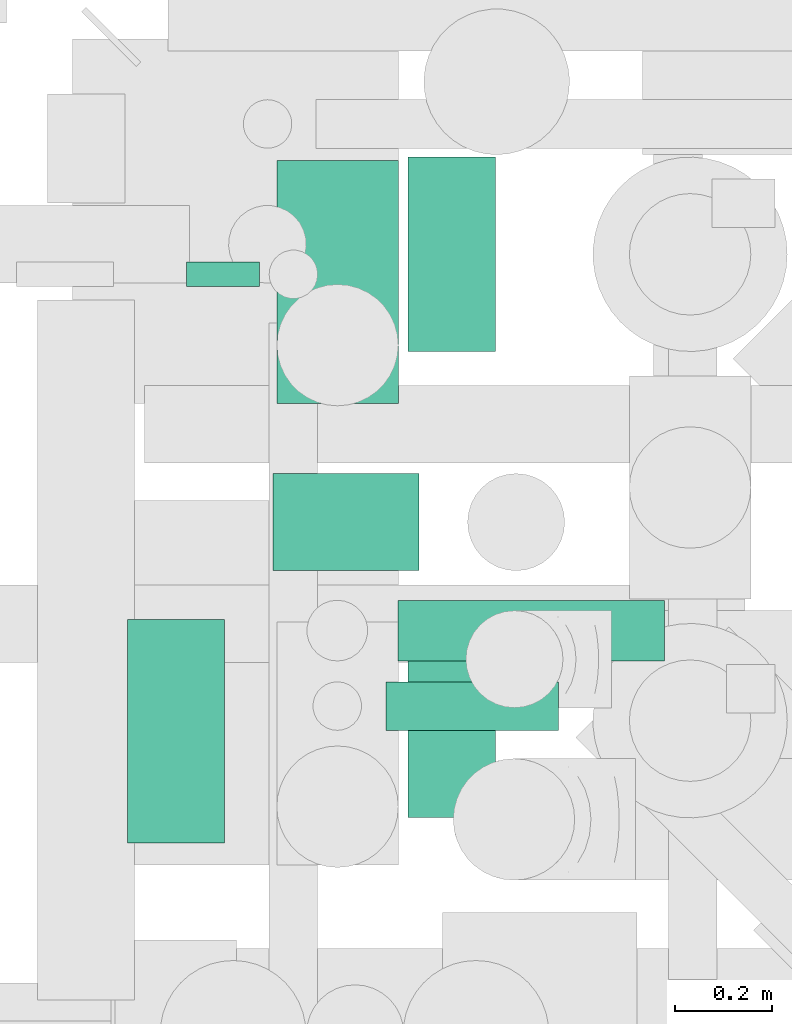
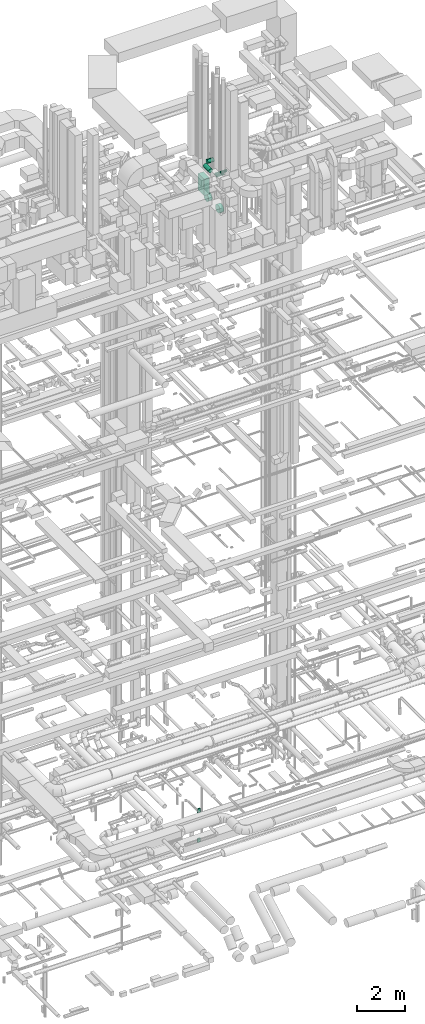
# One storey, part 226 of 337: 9 flow segments.
"""IFC2X3 building model written with IfcOpenShell, lengths in millimetres."""

from ifc_helpers import new_model, entity, si_unit, converted_unit, derived_unit, direction, frame, origin, origin_2d_with_axis, place, context, subcontext, project, spatial, rectangle, circle, extrude, type_object, element, save


model = new_model("IFC2X3")

# Units and contexts
model_context = context("Model", 3, precision=0.01, world=origin(), true_north=direction((6.12303176911189e-17, 1.0)))
body_context = subcontext(model_context, "Body", "Model", "MODEL_VIEW")
ifc_project = project(units=[si_unit("LENGTHUNIT", "METRE", prefix="MILLI"), si_unit("AREAUNIT", "SQUARE_METRE"), si_unit("VOLUMEUNIT", "CUBIC_METRE"), converted_unit("PLANEANGLEUNIT", "DEGREE", entity("IfcRatioMeasure", 0.0174532925199433), si_unit("PLANEANGLEUNIT", "RADIAN"), dimensions=[0, 0, 0, 0, 0, 0, 0]), si_unit("MASSUNIT", "GRAM", prefix="KILO"), derived_unit("MASSDENSITYUNIT", [(si_unit("MASSUNIT", "GRAM", prefix="KILO"), 1), (si_unit("LENGTHUNIT", "METRE"), -3)]), derived_unit("MOMENTOFINERTIAUNIT", [(si_unit("LENGTHUNIT", "METRE"), 4)]), si_unit("TIMEUNIT", "SECOND"), si_unit("FREQUENCYUNIT", "HERTZ"), si_unit("THERMODYNAMICTEMPERATUREUNIT", "DEGREE_CELSIUS"), derived_unit("THERMALTRANSMITTANCEUNIT", [(si_unit("MASSUNIT", "GRAM", prefix="KILO"), 1), (si_unit("THERMODYNAMICTEMPERATUREUNIT", "KELVIN"), -1), (si_unit("TIMEUNIT", "SECOND"), -3)]), derived_unit("VOLUMETRICFLOWRATEUNIT", [(si_unit("LENGTHUNIT", "METRE"), 3), (si_unit("TIMEUNIT", "SECOND"), -1)]), derived_unit("MASSFLOWRATEUNIT", [(si_unit("MASSUNIT", "GRAM", prefix="KILO"), 1), (si_unit("TIMEUNIT", "SECOND"), -1)]), derived_unit("ROTATIONALFREQUENCYUNIT", [(si_unit("TIMEUNIT", "SECOND"), -1)]), si_unit("ELECTRICCURRENTUNIT", "AMPERE"), si_unit("ELECTRICVOLTAGEUNIT", "VOLT"), si_unit("POWERUNIT", "WATT"), si_unit("FORCEUNIT", "NEWTON", prefix="KILO"), si_unit("ILLUMINANCEUNIT", "LUX"), si_unit("LUMINOUSFLUXUNIT", "LUMEN"), si_unit("LUMINOUSINTENSITYUNIT", "CANDELA"), derived_unit("USERDEFINED", [(si_unit("MASSUNIT", "GRAM", prefix="KILO"), -1), (si_unit("LENGTHUNIT", "METRE"), -2), (si_unit("TIMEUNIT", "SECOND"), 3), (si_unit("LUMINOUSFLUXUNIT", "LUMEN"), 1)]), derived_unit("LINEARVELOCITYUNIT", [(si_unit("LENGTHUNIT", "METRE"), 1), (si_unit("TIMEUNIT", "SECOND"), -1)]), si_unit("PRESSUREUNIT", "PASCAL"), derived_unit("USERDEFINED", [(si_unit("LENGTHUNIT", "METRE"), -2), (si_unit("MASSUNIT", "GRAM", prefix="KILO"), 1), (si_unit("TIMEUNIT", "SECOND"), -2)]), derived_unit("LINEARFORCEUNIT", [(si_unit("MASSUNIT", "GRAM", prefix="KILO"), 1), (si_unit("LENGTHUNIT", "METRE"), 1), (si_unit("TIMEUNIT", "SECOND"), -2), (si_unit("LENGTHUNIT", "METRE"), -1)]), derived_unit("PLANARFORCEUNIT", [(si_unit("MASSUNIT", "GRAM", prefix="KILO"), 1), (si_unit("LENGTHUNIT", "METRE"), 1), (si_unit("TIMEUNIT", "SECOND"), -2), (si_unit("LENGTHUNIT", "METRE"), -2)])], contexts=[model_context])

# Site, building, storey
site_placement = place(None, origin())
site = spatial("IfcSite", under=ifc_project, at=site_placement, CompositionType="ELEMENT")
building_placement = place(site_placement, origin())
building = spatial("IfcBuilding", under=site, at=building_placement, CompositionType="ELEMENT")
storey_placement = place(building_placement, origin())
storey = spatial("IfcBuildingStorey", under=building, at=storey_placement, CompositionType="ELEMENT", Elevation=0.0)

# Flow segments
duct_segment_type_1 = type_object("IfcDuctSegmentType", PredefinedType="NOTDEFINED")
for number, where in (
    (1, (55283.91, 11771.17, -3600.0)),
    (2, (55283.91, 11771.17, -2100.0)),
):
    element("IfcFlowSegment", number, at=place(storey_placement, frame(where)), inside=storey, type_object=duct_segment_type_1, context=body_context, shape_type="SweptSolid", body=[
        extrude(rectangle(XDim=149.999999999992, YDim=49.9999999999995, at=origin_2d_with_axis()), frame((75.0, 25.0, 0.0), z_axis=(0.0, 0.0, 1.0), x_axis=(-1.0, 0.0, 0.0)), (0.0, 0.0, 1.0), 200.0),
    ])
flow_segment_1_placement = place(storey_placement, frame((55470.02, 11530.6, 29220.0)))
element("IfcFlowSegment", 3, at=flow_segment_1_placement, inside=storey, type_object=duct_segment_type_1, context=body_context, shape_type="SweptSolid", body=[
    extrude(rectangle(XDim=249.999999999995, YDim=500.000000000001, at=origin_2d_with_axis()), frame((125.0, 250.0, 0.0)), (0.0, 0.0, 1.0), 828.55629679781),
])
duct_segment_type_2 = type_object("IfcDuctSegmentType", PredefinedType="NOTDEFINED")
flow_segment_2_placement = place(storey_placement, frame((55160.9, 10626.24, 30998.4)))
element("IfcFlowSegment", 4, at=flow_segment_2_placement, inside=storey, type_object=duct_segment_type_2, context=body_context, shape_type="SweptSolid", body=[
    extrude(circle(Radius=100.0, at=origin_2d_with_axis()), frame((101.6, 0.0, 101.6), z_axis=(0.0, 1.0, 0.0), x_axis=(1.0, 0.0, 0.0)), (0.0, 0.0, 1.0), 460.000000000008),
])
flow_segment_3_placement = place(storey_placement, frame((55462.5, 11184.64, 30998.4)))
element("IfcFlowSegment", 5, at=flow_segment_3_placement, inside=storey, type_object=duct_segment_type_2, context=body_context, shape_type="SweptSolid", body=[
    extrude(circle(Radius=100.0, at=origin_2d_with_axis()), frame((0.0, 101.6, 101.6), z_axis=(1.0, 0.0, 0.0), x_axis=(0.0, -1.0, 0.0)), (0.0, 0.0, 1.0), 300.000000000018),
])
flow_segment_4_placement = place(storey_placement, frame((55719.42, 10998.9, 30435.9)))
element("IfcFlowSegment", 6, at=flow_segment_4_placement, inside=storey, type_object=duct_segment_type_2, context=body_context, shape_type="SweptSolid", body=[
    extrude(circle(Radius=62.5, at=origin_2d_with_axis()), frame((0.0, 64.1, 64.1), z_axis=(1.0, 0.0, 0.0), x_axis=(0.0, -1.0, 0.0)), (0.0, 0.0, 1.0), 548.120199095578),
])
flow_segment_5_placement = place(storey_placement, frame((55694.42, 10856.12, 30453.4)))
element("IfcFlowSegment", 7, at=flow_segment_5_placement, inside=storey, type_object=duct_segment_type_2, context=body_context, shape_type="SweptSolid", body=[
    extrude(circle(Radius=50.0, at=origin_2d_with_axis()), frame((0.0, 51.6, 51.6), z_axis=(1.0, 0.0, 0.0), x_axis=(0.0, -1.0, 0.0)), (0.0, 0.0, 1.0), 355.762825380823),
])
flow_segment_6_placement = place(storey_placement, frame((55740.02, 10676.1, 28663.4)))
element("IfcFlowSegment", 8, at=flow_segment_6_placement, inside=storey, type_object=duct_segment_type_2, context=body_context, shape_type="SweptSolid", body=[
    extrude(circle(Radius=200.0, at=origin_2d_with_axis()), frame((0.0, 201.6, 201.6), z_axis=(1.0, 0.0, 0.0), x_axis=(0.0, 1.0, 0.0)), (0.0, 0.0, 1.0), 180.475680502015),
])
flow_segment_7_placement = place(storey_placement, frame((55740.02, 11635.78, 28663.4)))
element("IfcFlowSegment", 9, at=flow_segment_7_placement, inside=storey, type_object=duct_segment_type_2, context=body_context, shape_type="SweptSolid", body=[
    extrude(circle(Radius=200.0, at=origin_2d_with_axis()), frame((0.0, 201.6, 201.6), z_axis=(1.0, 0.0, 0.0), x_axis=(0.0, 1.0, 0.0)), (0.0, 0.0, 1.0), 180.475680502023),
])

save(model, "model.ifc")
